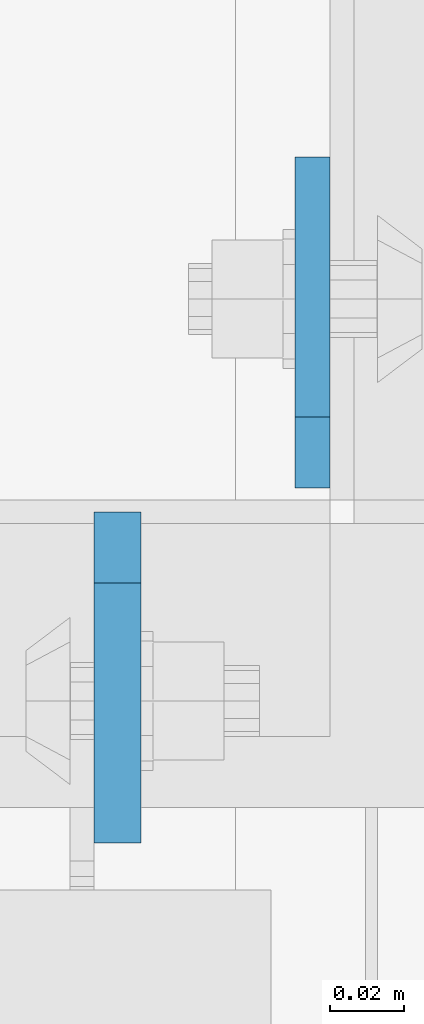
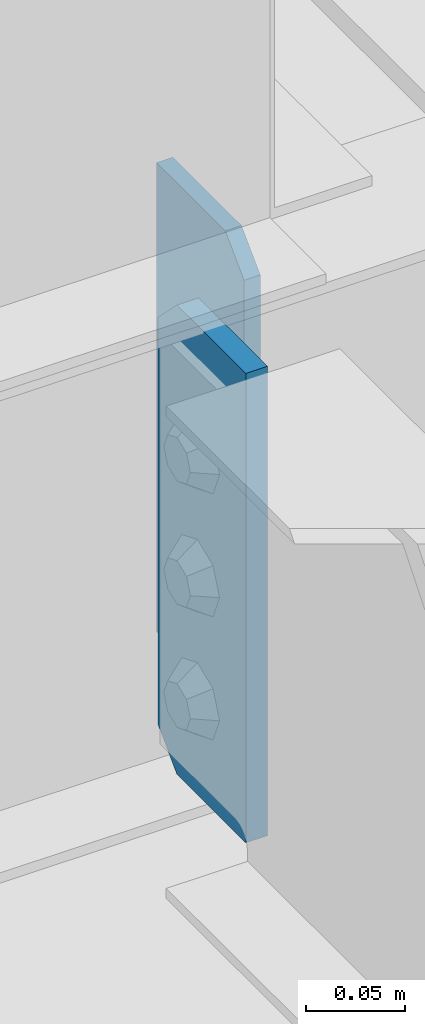
# One storey, part 1439 of 1876: 2 plates, 1 element without a shape of its own.
"""IFC2X3 building model written with IfcOpenShell, lengths in millimetres."""

from ifc_helpers import new_model, si_unit, frame, origin_with_axes, place, context, subcontext, project, spatial, faceted_brep, material, type_object, element, aggregate, save


model = new_model("IFC2X3")

# Units and contexts
model_context = context("Model", 3, precision=1e-05, world=origin_with_axes())
body_context = subcontext(model_context, "Body", "Model", "MODEL_VIEW")
ifc_project = project(units=[si_unit("LENGTHUNIT", "METRE", prefix="MILLI"), si_unit("AREAUNIT", "SQUARE_METRE"), si_unit("VOLUMEUNIT", "CUBIC_METRE"), si_unit("MASSUNIT", "GRAM", prefix="KILO"), si_unit("TIMEUNIT", "SECOND"), si_unit("PLANEANGLEUNIT", "RADIAN"), si_unit("SOLIDANGLEUNIT", "STERADIAN"), si_unit("THERMODYNAMICTEMPERATUREUNIT", "DEGREE_CELSIUS"), si_unit("LUMINOUSINTENSITYUNIT", "LUMEN")], contexts=[model_context])

# Site, building, storey
site_placement = place(None, origin_with_axes())
site = spatial("IfcSite", under=ifc_project, at=site_placement, CompositionType="ELEMENT")
building_placement = place(site_placement, origin_with_axes())
building = spatial("IfcBuilding", under=site, at=building_placement, Name="Undefined", CompositionType="ELEMENT")
storey_placement = place(building_placement, origin_with_axes())
storey = spatial("IfcBuildingStorey", under=building, at=storey_placement, Name="Undefined", CompositionType="ELEMENT", Elevation=0.0)

# Assembly, plates
assembly_placement = place(storey_placement, origin_with_axes())
assembly = element("IfcElementAssembly", 1, at=assembly_placement, inside=storey, Name="BEAM", AssemblyPlace="NOTDEFINED", PredefinedType="RIGID_FRAME")
ifc_material = material(Name="STEEL/A36")
plate_type_1 = type_object("IfcPlateType", PredefinedType="NOTDEFINED")
plate_1_placement = place(assembly_placement, frame((2417.7625, -6245.225, 22258.3375), z_axis=(0.0, 0.0, 1.0), x_axis=(0.0, 1.0, 0.0)))
plate_1 = element("IfcPlate", 2, at=plate_1_placement, type_object=plate_type_1, material=ifc_material, Name="PLATE", context=body_context, shape_type="Brep", body=[
    faceted_brep([(0.0, -4.76249999999982, 19.0499992370605), (0.0, -4.76249999999982, 271.462512969971), (0.0, 4.76249999999982, 271.462512969971), (0.0, 4.76249999999982, 19.0499992370605), (19.0499992370605, -4.76249999999982, 290.512512207031), (19.0499992370605, 4.76249999999982, 290.512512207031), (88.9000015258789, -4.76249999999982, 290.512512207031), (88.9000015258789, 4.76249999999982, 290.512512207031), (88.9000015258789, -4.76249999999982, 0.0), (88.9000015258789, 4.76249999999982, 0.0), (19.0499992370605, -4.76249999999982, 0.0), (19.0499992370605, 4.76249999999982, 0.0)], [[[0, 1, 2, 3]], [[1, 4, 5, 2]], [[4, 6, 7, 5]], [[6, 8, 9, 7]], [[8, 10, 11, 9]], [[10, 0, 3, 11]], [[5, 7, 9, 11, 3, 2]], [[10, 8, 6, 4, 1, 0]]]),
])
plate_type_2 = type_object("IfcPlateType", PredefinedType="NOTDEFINED")
plate_2_placement = place(assembly_placement, frame((2365.37500009537, -6251.575, 22258.3375), z_axis=(0.0, 0.0, 1.0), x_axis=(0.0, -1.0, 0.0)))
plate_2 = element("IfcPlate", 3, at=plate_2_placement, type_object=plate_type_2, material=ifc_material, Name="PLATE", context=body_context, shape_type="Brep", body=[
    faceted_brep([(0.0, -6.35000000000196, 19.0499992370605), (0.0, -6.35000000000036, 271.462512969971), (0.0, 6.35000000000036, 271.462512969971), (0.0, 6.35000000000105, 19.0499992370605), (19.0499992370605, -6.35000000000036, 290.512512207031), (19.0499992370605, 6.35000000000036, 290.512512207031), (88.9000015258789, -6.35000000000036, 290.512512207031), (88.9000015258789, 6.35000000000036, 290.512512207031), (88.9000015258789, -6.34999999999991, 0.0), (88.9000015258789, 6.34999999999991, 0.0), (19.0499992370642, -6.35000000000105, 0.0), (19.0499992370633, 6.35000000000105, 0.0)], [[[0, 1, 2, 3]], [[1, 4, 5, 2]], [[4, 6, 7, 5]], [[6, 8, 9, 7]], [[8, 10, 11, 9]], [[10, 0, 3, 11]], [[5, 7, 9, 11, 3, 2]], [[10, 8, 6, 4, 1, 0]]]),
])
aggregate(assembly, [plate_1, plate_2])

save(model, "model.ifc")
